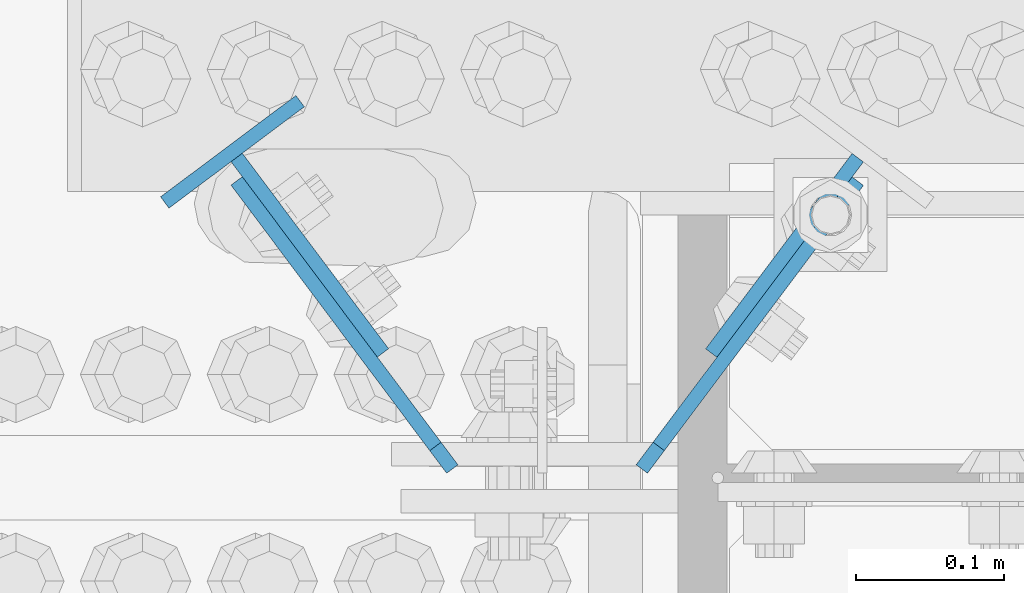
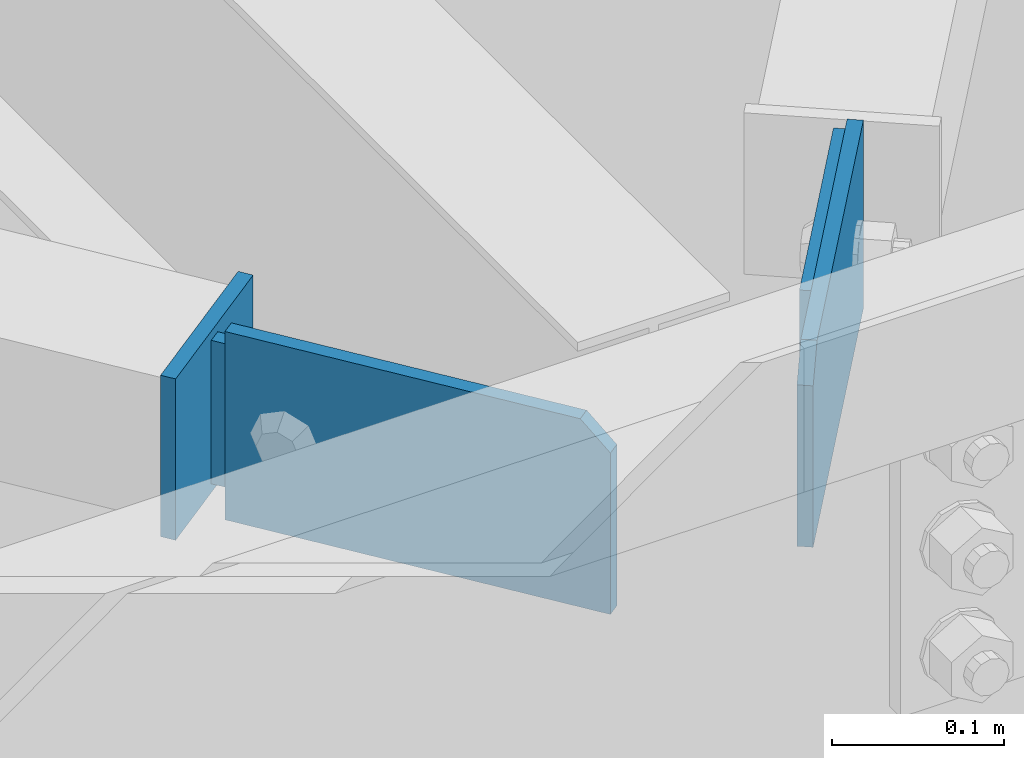
# One storey, part 957 of 1763: 5 columns, 3 elements without a shape of their own.
"""IFC2X3 building model written with IfcOpenShell, lengths in millimetres."""

from ifc_helpers import new_model, si_unit, frame, origin_with_axes, place, context, subcontext, project, spatial, faceted_brep, material, type_object, element, aggregate, save


model = new_model("IFC2X3")

# Units and contexts
model_context = context("Model", 3, precision=1e-05, world=origin_with_axes())
body_context = subcontext(model_context, "Body", "Model", "MODEL_VIEW")
ifc_project = project(units=[si_unit("LENGTHUNIT", "METRE", prefix="MILLI"), si_unit("AREAUNIT", "SQUARE_METRE"), si_unit("VOLUMEUNIT", "CUBIC_METRE"), si_unit("MASSUNIT", "GRAM", prefix="KILO"), si_unit("TIMEUNIT", "SECOND"), si_unit("PLANEANGLEUNIT", "RADIAN"), si_unit("SOLIDANGLEUNIT", "STERADIAN"), si_unit("THERMODYNAMICTEMPERATUREUNIT", "DEGREE_CELSIUS"), si_unit("LUMINOUSINTENSITYUNIT", "LUMEN")], contexts=[model_context])

# Site, building, storey
site_placement = place(None, origin_with_axes())
site = spatial("IfcSite", under=ifc_project, at=site_placement, CompositionType="ELEMENT")
building_placement = place(site_placement, origin_with_axes())
building = spatial("IfcBuilding", under=site, at=building_placement, Name="Undefined", CompositionType="ELEMENT")
storey_placement = place(building_placement, origin_with_axes())
storey = spatial("IfcBuildingStorey", under=building, at=storey_placement, Name="Undefined", CompositionType="ELEMENT", Elevation=0.0)

# Assembly, column
assembly_1_placement = place(storey_placement, origin_with_axes())
assembly_1 = element("IfcElementAssembly", 1, at=assembly_1_placement, inside=storey, Name="H. BRACE", AssemblyPlace="NOTDEFINED", PredefinedType="RIGID_FRAME")
ifc_material = material(Name="STEEL/A36")
column_type_1 = type_object("IfcColumnType", PredefinedType="NOTDEFINED")
column_1_placement = place(assembly_1_placement, frame((-35608.2337167669, 52341.2768443083, 12428.5375), z_axis=(0.800546116056367, 0.599271154042197, 0.0), x_axis=(0.0, 0.0, -1.0)))
column_1 = element("IfcColumn", 2, at=column_1_placement, type_object=column_type_1, material=ifc_material, Name="PLATE", context=body_context, shape_type="Brep", body=[
    faceted_brep([(0.0, 4.76249999989523, -57.1500000001702), (0.0, 4.76250000014261, 57.1500000001565), (114.299999999999, 4.76250000014261, 57.1500000001565), (114.299999999999, 4.76249999989523, -57.1500000001702), (0.0, -4.76249999988067, 57.1500000001784), (114.299999999999, -4.76249999988067, 57.1500000001784), (0.0, -4.76250000012806, -57.150000000152), (114.299999999999, -4.76250000012806, -57.150000000152)], [[[0, 1, 2, 3]], [[1, 4, 5, 2]], [[4, 6, 7, 5]], [[6, 0, 3, 7]], [[5, 7, 3, 2]], [[6, 4, 1, 0]]]),
])

assembly_2_placement = place(storey_placement, origin_with_axes())
assembly_2 = element("IfcElementAssembly", 3, at=assembly_2_placement, inside=storey, Name="H. BRACE", AssemblyPlace="NOTDEFINED", PredefinedType="RIGID_FRAME")
column_type_2 = type_object("IfcColumnType", PredefinedType="NOTDEFINED")
column_2_placement = place(assembly_2_placement, frame((-35234.953089471, 52271.2772802919, 12422.1875), z_axis=(-0.600137979714526, -0.799896496619511, 0.0), x_axis=(0.0, 0.0, -1.0)))
column_2 = element("IfcColumn", 4, at=column_2_placement, type_object=column_type_2, material=ifc_material, Name="PLATE", context=body_context, shape_type="Brep", body=[
    faceted_brep([(0.0, 4.7625000001417, -82.5500000001048), (0.0, 4.76249999986885, 82.5500000001339), (101.599999999999, 4.76249999986885, 82.5500000001339), (101.599999999999, 4.7625000001417, -82.5500000001048), (0.0, -4.76250000014352, 82.5500000001193), (101.599999999999, -4.76250000014352, 82.5500000001193), (0.0, -4.76249999987067, -82.5500000001193), (101.599999999999, -4.76249999987067, -82.5500000001193)], [[[0, 1, 2, 3]], [[1, 4, 5, 2]], [[4, 6, 7, 5]], [[6, 0, 3, 7]], [[5, 7, 3, 2]], [[6, 4, 1, 0]]]),
])
aggregate(assembly_2, [column_2])

# Column
column_3_placement = place(assembly_1_placement, frame((-35555.9158468407, 52271.387167011, 12422.1875), z_axis=(0.599271154042184, -0.800546116056376, 0.0), x_axis=(0.0, 0.0, -1.0)))
column_3 = element("IfcColumn", 5, at=column_3_placement, type_object=column_type_2, material=ifc_material, Name="PLATE", context=body_context, shape_type="Brep", body=[
    faceted_brep([(0.0, 4.76249999983474, -82.5385000002425), (0.0, 4.7625000001949, 82.5385000002425), (101.599999999999, 4.7625000001949, 82.5385000002425), (101.599999999999, 4.76249999983474, -82.5385000002425), (0.0, -4.76249999983202, 82.538500000257), (101.599999999999, -4.76249999983202, 82.538500000257), (0.0, -4.76250000019945, -82.5385000002134), (101.599999999999, -4.76250000019945, -82.5385000002134)], [[[0, 1, 2, 3]], [[1, 4, 5, 2]], [[4, 6, 7, 5]], [[6, 0, 3, 7]], [[5, 7, 3, 2]], [[6, 4, 1, 0]]]),
])

aggregate(assembly_1, [column_3, column_1])

# Assembly, columns
assembly_3_placement = place(storey_placement, origin_with_axes())
assembly_3 = element("IfcElementAssembly", 6, at=assembly_3_placement, inside=storey, Name="BEAM", AssemblyPlace="NOTDEFINED", PredefinedType="RIGID_FRAME")
column_type_3 = type_object("IfcColumnType", PredefinedType="NOTDEFINED")
column_4_placement = place(assembly_3_placement, frame((-35258.415221309, 52224.1343264769, 12438.0625), z_axis=(-0.600137979714526, -0.799896496619511, 0.0), x_axis=(0.0, 0.0, -1.0)))
column_4 = element("IfcColumn", 7, at=column_4_placement, type_object=column_type_3, material=ifc_material, Name="PLATE", context=body_context, shape_type="Brep", body=[
    faceted_brep([(0.0, -4.76250000028085, 102.591999999917), (19.0499999999993, -4.76250000032451, 121.641999999894), (19.0499999999993, 4.76249999966967, 121.64199999992), (0.0, 4.76249999971333, 102.591999999942), (133.349999999999, 4.76249999966967, 121.64199999992), (133.349999999999, 4.76250000032451, -121.641999999894), (0.0, 4.76250000032451, -121.641999999894), (133.349999999999, -4.76250000032451, 121.641999999894), (0.0, -4.76249999966967, -121.64199999992), (133.349999999999, -4.76249999966967, -121.64199999992)], [[[0, 1, 2, 3]], [[4, 5, 6, 3, 2]], [[7, 4, 2, 1]], [[8, 9, 7, 1, 0]], [[8, 6, 5, 9]], [[7, 9, 5, 4]], [[6, 8, 0, 3]]]),
])
column_5_placement = place(assembly_3_placement, frame((-35532.4976042708, 52224.2092193597, 12438.0625), z_axis=(0.599271154042184, -0.800546116056376, 0.0), x_axis=(0.0, 0.0, -1.0)))
column_5 = element("IfcColumn", 8, at=column_5_placement, type_object=column_type_3, material=ifc_material, Name="PLATE", context=body_context, shape_type="Brep", body=[
    faceted_brep([(0.0, -4.76250000028085, 102.591999999917), (19.0499999999993, -4.76250000032451, 121.641999999894), (19.0499999999993, 4.76249999966967, 121.64199999992), (0.0, 4.76249999971333, 102.591999999942), (133.349999999999, 4.76249999966967, 121.64199999992), (133.349999999999, 4.76250000032451, -121.641999999894), (0.0, 4.76250000032451, -121.641999999894), (133.349999999999, -4.76250000032451, 121.641999999894), (0.0, -4.76249999966967, -121.64199999992), (133.349999999999, -4.76249999966967, -121.64199999992)], [[[0, 1, 2, 3]], [[4, 5, 6, 3, 2]], [[7, 4, 2, 1]], [[8, 9, 7, 1, 0]], [[8, 6, 5, 9]], [[7, 9, 5, 4]], [[6, 8, 0, 3]]]),
])
aggregate(assembly_3, [column_4, column_5])

save(model, "model.ifc")
